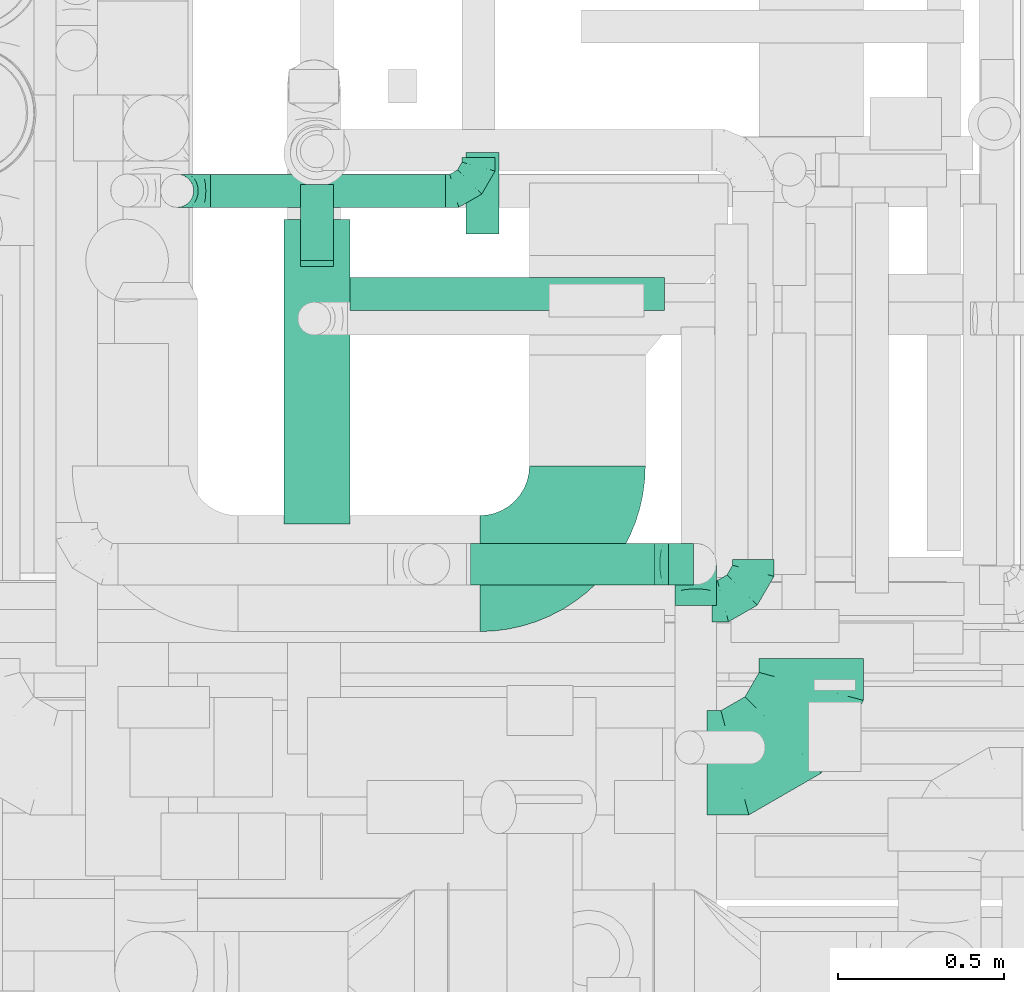
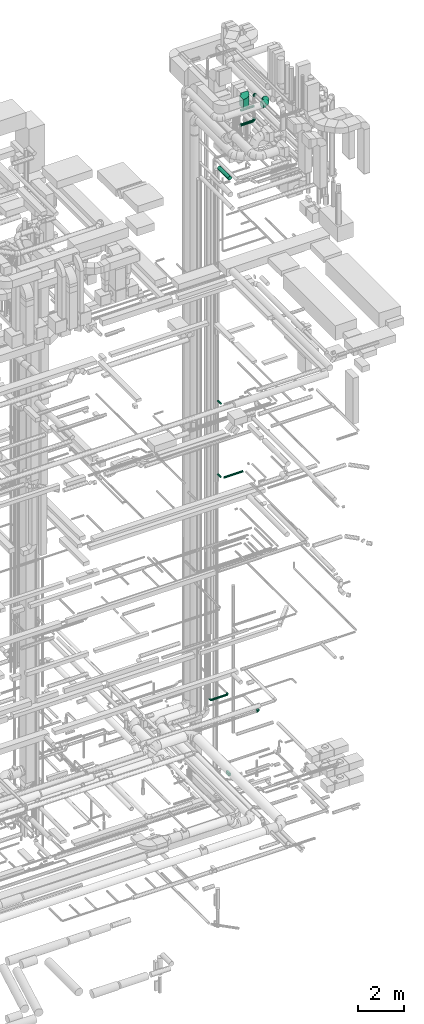
# One storey, part 264 of 337: 8 flow fittings, 8 flow segments.
"""IFC2X3 building model written with IfcOpenShell, lengths in millimetres."""

import ifcopenshell
import ifcopenshell.guid

model = None  # the IFC model being written
_history = None  # IfcOwnerHistory: only IFC2X3 demands one
_inside = {}  # id of a spatial element -> (the spatial element, [elements in it])
_under = {}  # id of a project, library or spatial element -> (it, [spatial elements below it])
_declared = {}  # id of a project -> (the project, [libraries it declares])
_typed = {}  # id of a type object -> (the type object, [elements of that type])
_made_of = {}  # id of a material, layer set ... -> (it, [elements and type objects made of it])


def new_model(schema):
    """Start an empty IFC model of exactly this schema.

    Asked for "IFC4X3", IfcOpenShell would pick the latest addendum, in which some entities
    have other attributes; the version numbers below select the first issue.
    IFC2X3 requires an IfcOwnerHistory on every rooted entity: one is made here for all.
    """
    global model, _history
    if schema == "IFC4X3":
        model = ifcopenshell.file(schema_version=(4, 3, 0, 0))
    else:
        model = ifcopenshell.file(schema=schema)
    _inside.clear()
    _under.clear()
    _declared.clear()
    _typed.clear()
    _made_of.clear()
    _history = None
    if model.schema == "IFC2X3":
        org = make("IfcOrganization", Name="unknown")
        user = make(
            "IfcPersonAndOrganization",
            ThePerson=make("IfcPerson", FamilyName="unknown"),
            TheOrganization=org,
        )
        app = make(
            "IfcApplication",
            ApplicationDeveloper=org,
            Version="unknown",
            ApplicationFullName="unknown",
            ApplicationIdentifier="unknown",
        )
        _history = make(
            "IfcOwnerHistory",
            OwningUser=user,
            OwningApplication=app,
            ChangeAction="ADDED",
            CreationDate=0,
        )
    return model


def make(cls, **values):
    """One entity of the class cls with the attributes given. An attribute that is None is left unset."""
    return model.create_entity(
        cls, **{name: value for name, value in values.items() if value is not None}
    )


def entity(cls, *values):
    """Any entity or typed value of the class cls, its attributes in the order of the schema. None: left unset."""
    e = model.create_entity(cls)
    for i, value in enumerate(values):
        if value is not None:
            e[i] = value
    return e


def rooted(cls, **values):
    """An entity with a GlobalId (a new one), such as an element, a storey or a relation."""
    return make(cls, GlobalId=ifcopenshell.guid.new(), OwnerHistory=_history, **values)


def si_unit(unit_type, name, prefix=None):
    """IfcSIUnit, for example si_unit("LENGTHUNIT", "METRE", prefix="MILLI")."""
    return make("IfcSIUnit", UnitType=unit_type, Prefix=prefix, Name=name)


def converted_unit(unit_type, name, factor, base, dimensions=None, offset=None):
    """IfcConversionBasedUnit, such as the inch: factor (a typed value) times the base unit."""
    return make(
        "IfcConversionBasedUnit"
        if offset is None
        else "IfcConversionBasedUnitWithOffset",
        ConversionOffset=offset,
        Dimensions=None
        if dimensions is None
        else entity("IfcDimensionalExponents", *dimensions),
        UnitType=unit_type,
        Name=name,
        ConversionFactor=make(
            "IfcMeasureWithUnit", ValueComponent=factor, UnitComponent=base
        ),
    )


def derived_unit(unit_type, elements):
    """IfcDerivedUnit: a product of units, each with its exponent."""
    return make(
        "IfcDerivedUnit",
        Elements=[
            make("IfcDerivedUnitElement", Unit=unit, Exponent=power)
            for unit, power in elements
        ],
        UnitType=unit_type,
    )


def assignment(units):
    """IfcUnitAssignment: the units of a project."""
    return None if units is None else make("IfcUnitAssignment", Units=units)


def point(xyz):
    """IfcCartesianPoint."""
    return None if xyz is None else make("IfcCartesianPoint", Coordinates=xyz)


def direction(xyz):
    """IfcDirection."""
    return None if xyz is None else make("IfcDirection", DirectionRatios=xyz)


def frame(location, z_axis=None, x_axis=None):
    """IfcAxis2Placement3D, a coordinate frame: its origin and axes. An axis left out is left unset."""
    return make(
        "IfcAxis2Placement3D",
        Location=point(location),
        Axis=direction(z_axis),
        RefDirection=direction(x_axis),
    )


def frame_2d(location, x_axis=None):
    """IfcAxis2Placement2D, a coordinate frame in the plane: its origin and x axis."""
    return make(
        "IfcAxis2Placement2D", Location=point(location), RefDirection=direction(x_axis)
    )


def origin():
    """The frame at (0, 0, 0) with its axes left unset."""
    return frame((0.0, 0.0, 0.0))


def origin_2d_with_axis():
    """The frame at (0, 0) in the plane with the x axis (1, 0) written out."""
    return frame_2d((0.0, 0.0), x_axis=(1.0, 0.0))


def place(relative_to, where):
    """IfcLocalPlacement: puts the frame where relative to a parent placement (None: the world)."""
    return make(
        "IfcLocalPlacement", PlacementRelTo=relative_to, RelativePlacement=where
    )


def context(
    kind, dimensions, precision=None, world=None, true_north=None, identifier=None
):
    """IfcGeometricRepresentationContext, for example the 3D "Model" context."""
    return make(
        "IfcGeometricRepresentationContext",
        ContextIdentifier=identifier,
        ContextType=kind,
        CoordinateSpaceDimension=dimensions,
        Precision=precision,
        WorldCoordinateSystem=world,
        TrueNorth=true_north,
    )


def subcontext(parent, identifier, kind, view, scale=None):
    """IfcGeometricRepresentationSubContext, for example "Body" below "Model"."""
    return make(
        "IfcGeometricRepresentationSubContext",
        ContextIdentifier=identifier,
        ContextType=kind,
        ParentContext=parent,
        TargetScale=scale,
        TargetView=view,
    )


def project(units=None, contexts=None):
    """IfcProject with its units and contexts."""
    return rooted(
        "IfcProject",
        Name="project",
        RepresentationContexts=contexts,
        UnitsInContext=assignment(units),
    )


def spatial(cls, under=None, at=None, **own):
    """A site, building, storey or space (cls), placed at a placement, below another one or the project."""
    s = rooted(cls, ObjectPlacement=at, **own)
    if under is not None:
        _under.setdefault(under.id(), (under, []))[1].append(s)
    return s


def polyline(points):
    """IfcPolyline through the points."""
    return make("IfcPolyline", Points=[point(p) for p in points])


def circle_curve(where, radius):
    """IfcCircle in the frame where."""
    return make("IfcCircle", Position=where, Radius=radius)


def parameter(value):
    """IfcParameterValue: where a trimmed curve begins or ends, as a parameter of its basis curve."""
    return model.create_entity("IfcParameterValue", value)


def trimmed(basis, trim1, trim2, sense, master):
    """IfcTrimmedCurve: the piece of a basis curve between two trims."""
    return make(
        "IfcTrimmedCurve",
        BasisCurve=basis,
        Trim1=trim1,
        Trim2=trim2,
        SenseAgreement=sense,
        MasterRepresentation=master,
    )


def segment(curve, same_sense, transition):
    """IfcCompositeCurveSegment."""
    return make(
        "IfcCompositeCurveSegment",
        Transition=transition,
        SameSense=same_sense,
        ParentCurve=curve,
    )


def composite_curve(segments, self_intersect=None):
    """IfcCompositeCurve: segments joined end to end."""
    return make("IfcCompositeCurve", Segments=segments, SelfIntersect=self_intersect)


def profile(cls, at=None, kind="AREA", **sizes):
    """A parametric profile (cls). Its sizes go by their IFC names, for example OverallWidth=200.0."""
    return make(cls, ProfileType=kind, Position=at, **sizes)


def rectangle(**sizes):
    """IfcRectangleProfileDef."""
    return profile("IfcRectangleProfileDef", **sizes)


def circle(**sizes):
    """IfcCircleProfileDef."""
    return profile("IfcCircleProfileDef", **sizes)


def outline(outer, holes=None, kind="AREA"):
    """IfcArbitraryClosedProfileDef: a profile drawn as a closed curve; with holes, ...WithVoids."""
    if holes is None:
        return make("IfcArbitraryClosedProfileDef", ProfileType=kind, OuterCurve=outer)
    return make(
        "IfcArbitraryProfileDefWithVoids",
        ProfileType=kind,
        OuterCurve=outer,
        InnerCurves=holes,
    )


def extrude(swept, where, along, depth):
    """IfcExtrudedAreaSolid: the profile swept, set in the frame where, extruded along a direction by depth."""
    return make(
        "IfcExtrudedAreaSolid",
        SweptArea=swept,
        Position=where,
        ExtrudedDirection=direction(along),
        Depth=depth,
    )


def faces_of(points, faces, orient=None, outer=None):
    """IfcFace entities. A face is a list of loops; a loop is a list of indices into points, from 0.

    orient and outer hold one flag for each loop. By default every Orientation is true, the
    first loop of a face is its IfcFaceOuterBound and the others are IfcFaceBound.
    """
    made = []
    for i, loops in enumerate(faces):
        bounds = []
        for j, loop in enumerate(loops):
            is_outer = j == 0 if outer is None else outer[i][j]
            bounds.append(
                make(
                    "IfcFaceOuterBound" if is_outer else "IfcFaceBound",
                    Bound=make("IfcPolyLoop", Polygon=[points[k] for k in loop]),
                    Orientation=True if orient is None else orient[i][j],
                )
            )
        made.append(make("IfcFace", Bounds=bounds))
    return made


def faceted_brep(points, faces, orient=None, outer=None, voids=None):
    """IfcFacetedBrep: a solid bounded by flat faces; with voids (closed shells), ...WithVoids."""
    shared = [point(p) for p in points]
    hull = make("IfcClosedShell", CfsFaces=faces_of(shared, faces, orient, outer))
    if voids is None:
        return make("IfcFacetedBrep", Outer=hull)
    return make(
        "IfcFacetedBrepWithVoids",
        Outer=hull,
        Voids=[
            make(cls, CfsFaces=faces_of(shared, fs, o, b)) for cls, fs, o, b in voids
        ],
    )


def shape(context_of_items, identifier, shape_type, items):
    """IfcShapeRepresentation: the items that make up one representation, for example the "Body"."""
    return make(
        "IfcShapeRepresentation",
        ContextOfItems=context_of_items,
        RepresentationIdentifier=identifier,
        RepresentationType=shape_type,
        Items=items,
    )


def source(mapping_origin, context_of_items, identifier, shape_type, items):
    """IfcRepresentationMap: a shape defined once, which mapped items show again and again."""
    return make(
        "IfcRepresentationMap",
        MappingOrigin=mapping_origin,
        MappedRepresentation=shape(context_of_items, identifier, shape_type, items),
    )


def transform(
    local_origin,
    x_axis=None,
    y_axis=None,
    z_axis=None,
    scale=None,
    scale2=None,
    scale3=None,
    uniform=True,
):
    """IfcCartesianTransformationOperator3D, or its non-uniform kind. x_axis, y_axis, z_axis: its Axis1, 2, 3."""
    if uniform:
        return make(
            "IfcCartesianTransformationOperator3D",
            Axis1=direction(x_axis),
            Axis2=direction(y_axis),
            LocalOrigin=point(local_origin),
            Scale=scale,
            Axis3=direction(z_axis),
        )
    return make(
        "IfcCartesianTransformationOperator3DnonUniform",
        Axis1=direction(x_axis),
        Axis2=direction(y_axis),
        LocalOrigin=point(local_origin),
        Scale=scale,
        Axis3=direction(z_axis),
        Scale2=scale2,
        Scale3=scale3,
    )


def mapped(mapping_source, mapping_target):
    """IfcMappedItem: shows the shape of a source again, moved by a transform."""
    return make(
        "IfcMappedItem", MappingSource=mapping_source, MappingTarget=mapping_target
    )


def material(Name=None, Category=None):
    """IfcMaterial."""
    return make("IfcMaterial", Name=Name, Category=Category)


def made_of(thing, what):
    """Note that an element or type object is made of a material, layer set ...; save() writes the relation."""
    if what is not None:
        _made_of.setdefault(what.id(), (what, []))[1].append(thing)
    return thing


def type_object(cls, material=None, **own):
    """A type object (cls), such as IfcWallType, which elements share."""
    return made_of(rooted(cls, **own), material)


def type_shapes(of_type, sources):
    """Give a type object the sources (RepresentationMaps) that its elements show as mapped items."""
    of_type.RepresentationMaps = sources


def element(
    cls,
    number,
    at=None,
    inside=None,
    cuts=None,
    type_object=None,
    material=None,
    context=None,
    identifier="Body",
    shape_type=None,
    held_by="IfcProductDefinitionShape",
    body=None,
    shapes=None,
    **own,
):
    """One element of the class cls, such as IfcWall. Its Tag is "e" and its number.

    at: its placement. inside: the storey or other place that contains it. cuts: it is an
    opening in that element (IfcRelVoidsElement). A single representation is given by context,
    identifier, shape_type and body (its items); several are given by shapes. held_by: the class
    of the entity that holds the representations. save() writes the other relations.
    """
    e = rooted(cls, Tag="e%d" % number, ObjectPlacement=at, **own)
    if body is not None:
        shapes = [shape(context, identifier, shape_type, body)]
    if shapes is not None:
        e.Representation = make(held_by, Representations=shapes)
    if inside is not None:
        _inside.setdefault(inside.id(), (inside, []))[1].append(e)
    if cuts is not None:
        rooted(
            "IfcRelVoidsElement", RelatingBuildingElement=cuts, RelatedOpeningElement=e
        )
    if type_object is not None:
        _typed.setdefault(type_object.id(), (type_object, []))[1].append(e)
    return made_of(e, material)


def aggregate(whole, parts):
    """IfcRelAggregates: a whole, such as a stair, and the parts it consists of."""
    return rooted("IfcRelAggregates", RelatingObject=whole, RelatedObjects=parts)


def save(model, path):
    """Write the relations noted so far, then the file.

    IfcRelAggregates (storeys below a building ...), IfcRelContainedInSpatialStructure (elements
    in a storey), IfcRelDefinesByType, IfcRelAssociatesMaterial and IfcRelDeclares: one each for
    every whole, place, type object, material and project.
    """
    for whole, parts in _under.values():
        aggregate(whole, parts)
    for where, things in _inside.values():
        rooted(
            "IfcRelContainedInSpatialStructure",
            RelatedElements=things,
            RelatingStructure=where,
        )
    for kind, things in _typed.values():
        rooted("IfcRelDefinesByType", RelatedObjects=things, RelatingType=kind)
    for what, things in _made_of.values():
        rooted("IfcRelAssociatesMaterial", RelatedObjects=things, RelatingMaterial=what)
    for by, libraries in _declared.values():
        rooted("IfcRelDeclares", RelatingContext=by, RelatedDefinitions=libraries)
    model.write(path)


model = new_model("IFC2X3")

# Units and contexts
model_context = context("Model", 3, precision=0.01, world=origin(), true_north=direction((6.12303176911189e-17, 1.0)))
body_context = subcontext(model_context, "Body", "Model", "MODEL_VIEW")
ifc_project = project(units=[si_unit("LENGTHUNIT", "METRE", prefix="MILLI"), si_unit("AREAUNIT", "SQUARE_METRE"), si_unit("VOLUMEUNIT", "CUBIC_METRE"), converted_unit("PLANEANGLEUNIT", "DEGREE", entity("IfcRatioMeasure", 0.0174532925199433), si_unit("PLANEANGLEUNIT", "RADIAN"), dimensions=[0, 0, 0, 0, 0, 0, 0]), si_unit("MASSUNIT", "GRAM", prefix="KILO"), derived_unit("MASSDENSITYUNIT", [(si_unit("MASSUNIT", "GRAM", prefix="KILO"), 1), (si_unit("LENGTHUNIT", "METRE"), -3)]), derived_unit("MOMENTOFINERTIAUNIT", [(si_unit("LENGTHUNIT", "METRE"), 4)]), si_unit("TIMEUNIT", "SECOND"), si_unit("FREQUENCYUNIT", "HERTZ"), si_unit("THERMODYNAMICTEMPERATUREUNIT", "DEGREE_CELSIUS"), derived_unit("THERMALTRANSMITTANCEUNIT", [(si_unit("MASSUNIT", "GRAM", prefix="KILO"), 1), (si_unit("THERMODYNAMICTEMPERATUREUNIT", "KELVIN"), -1), (si_unit("TIMEUNIT", "SECOND"), -3)]), derived_unit("VOLUMETRICFLOWRATEUNIT", [(si_unit("LENGTHUNIT", "METRE"), 3), (si_unit("TIMEUNIT", "SECOND"), -1)]), derived_unit("MASSFLOWRATEUNIT", [(si_unit("MASSUNIT", "GRAM", prefix="KILO"), 1), (si_unit("TIMEUNIT", "SECOND"), -1)]), derived_unit("ROTATIONALFREQUENCYUNIT", [(si_unit("TIMEUNIT", "SECOND"), -1)]), si_unit("ELECTRICCURRENTUNIT", "AMPERE"), si_unit("ELECTRICVOLTAGEUNIT", "VOLT"), si_unit("POWERUNIT", "WATT"), si_unit("FORCEUNIT", "NEWTON", prefix="KILO"), si_unit("ILLUMINANCEUNIT", "LUX"), si_unit("LUMINOUSFLUXUNIT", "LUMEN"), si_unit("LUMINOUSINTENSITYUNIT", "CANDELA"), derived_unit("USERDEFINED", [(si_unit("MASSUNIT", "GRAM", prefix="KILO"), -1), (si_unit("LENGTHUNIT", "METRE"), -2), (si_unit("TIMEUNIT", "SECOND"), 3), (si_unit("LUMINOUSFLUXUNIT", "LUMEN"), 1)]), derived_unit("LINEARVELOCITYUNIT", [(si_unit("LENGTHUNIT", "METRE"), 1), (si_unit("TIMEUNIT", "SECOND"), -1)]), si_unit("PRESSUREUNIT", "PASCAL"), derived_unit("USERDEFINED", [(si_unit("LENGTHUNIT", "METRE"), -2), (si_unit("MASSUNIT", "GRAM", prefix="KILO"), 1), (si_unit("TIMEUNIT", "SECOND"), -2)]), derived_unit("LINEARFORCEUNIT", [(si_unit("MASSUNIT", "GRAM", prefix="KILO"), 1), (si_unit("LENGTHUNIT", "METRE"), 1), (si_unit("TIMEUNIT", "SECOND"), -2), (si_unit("LENGTHUNIT", "METRE"), -1)]), derived_unit("PLANARFORCEUNIT", [(si_unit("MASSUNIT", "GRAM", prefix="KILO"), 1), (si_unit("LENGTHUNIT", "METRE"), 1), (si_unit("TIMEUNIT", "SECOND"), -2), (si_unit("LENGTHUNIT", "METRE"), -2)])], contexts=[model_context])

# Site, building, storey
site_placement = place(None, origin())
site = spatial("IfcSite", under=ifc_project, at=site_placement, CompositionType="ELEMENT")
building_placement = place(site_placement, origin())
building = spatial("IfcBuilding", under=site, at=building_placement, CompositionType="ELEMENT")
storey_placement = place(building_placement, origin())
storey = spatial("IfcBuildingStorey", under=building, at=storey_placement, CompositionType="ELEMENT", Elevation=0.0)

# Flow segments
duct_segment_type_1 = type_object("IfcDuctSegmentType", PredefinedType="NOTDEFINED")
flow_segment_1_placement = place(storey_placement, frame((69064.1, 11423.58, -750.0)))
element("IfcFlowSegment", 1, at=flow_segment_1_placement, inside=storey, type_object=duct_segment_type_1, context=body_context, shape_type="SweptSolid", body=[
    extrude(rectangle(XDim=246.447609999898, YDim=100.000000000003, at=origin_2d_with_axis()), frame((50.0, 123.22, 0.0), z_axis=(0.0, 0.0, 1.0), x_axis=(0.0, -1.0, 0.0)), (0.0, 0.0, 1.0), 150.0),
])
duct_segment_type_2 = type_object("IfcDuctSegmentType", PredefinedType="NOTDEFINED")
flow_segment_2_placement = place(storey_placement, frame((68714.23, 11191.71, 15248.4)))
element("IfcFlowSegment", 2, at=flow_segment_2_placement, inside=storey, type_object=duct_segment_type_2, context=body_context, shape_type="SweptSolid", body=[
    extrude(circle(Radius=50.0, at=origin_2d_with_axis()), frame((0.0, 51.6, 51.6), z_axis=(1.0, 0.0, 0.0), x_axis=(0.0, -1.0, 0.0)), (0.0, 0.0, 1.0), 949.254329999947),
])
flow_segment_3_placement = place(storey_placement, frame((68562.0, 11325.2, 19148.4)))
element("IfcFlowSegment", 3, at=flow_segment_3_placement, inside=storey, type_object=duct_segment_type_2, context=body_context, shape_type="SweptSolid", body=[
    extrude(circle(Radius=50.0, at=origin_2d_with_axis()), frame((51.6, 0.01, 51.6), z_axis=(0.000117343441141083, 0.999999993115258, 0.0), x_axis=(0.999999993115258, -0.000117343441141083, 0.0)), (0.0, 0.0, 1.0), 245.06931052787),
])
flow_segment_4_placement = place(storey_placement, frame((68562.63, 11343.31, 15248.4)))
element("IfcFlowSegment", 4, at=flow_segment_4_placement, inside=storey, type_object=duct_segment_type_2, context=body_context, shape_type="SweptSolid", body=[
    extrude(circle(Radius=50.0, at=origin_2d_with_axis()), frame((51.6, 0.0, 51.6), z_axis=(0.0, 1.0, 0.0), x_axis=(-1.0, 0.0, 0.0)), (0.0, 0.0, 1.0), 230.074907633675),
])
flow_segment_5_placement = place(storey_placement, frame((68291.62, 11502.7, 3448.4)))
element("IfcFlowSegment", 5, at=flow_segment_5_placement, inside=storey, type_object=duct_segment_type_2, context=body_context, shape_type="SweptSolid", body=[
    extrude(circle(Radius=50.0, at=origin_2d_with_axis()), frame((0.0, 51.6, 51.6), z_axis=(1.0, 0.0, 0.0), x_axis=(0.0, 1.0, 0.0)), (0.0, 0.0, 1.0), 710.00000000002),
])
flow_segment_6_placement = place(storey_placement, frame((69077.45, 10363.17, 35035.9)))
element("IfcFlowSegment", 6, at=flow_segment_6_placement, inside=storey, type_object=duct_segment_type_2, context=body_context, shape_type="SweptSolid", body=[
    extrude(circle(Radius=62.5, at=origin_2d_with_axis()), frame((0.0, 64.1, 64.1), z_axis=(1.0, 0.0, 0.0), x_axis=(0.0, 1.0, 0.0)), (0.0, 0.0, 1.0), 597.499999999864),
])
flow_segment_7_placement = place(storey_placement, frame((69064.95, 10363.17, 34255.9)))
element("IfcFlowSegment", 7, at=flow_segment_7_placement, inside=storey, type_object=duct_segment_type_2, context=body_context, shape_type="SweptSolid", body=[
    extrude(circle(Radius=62.5, at=origin_2d_with_axis()), frame((0.0, 64.1, 64.1), z_axis=(1.0, 0.0, 0.0), x_axis=(0.0, 1.0, 0.0)), (0.0, 0.0, 1.0), 567.49999999988),
])
flow_segment_8_placement = place(storey_placement, frame((68512.03, 10548.42, 31498.4)))
element("IfcFlowSegment", 8, at=flow_segment_8_placement, inside=storey, type_object=duct_segment_type_2, context=body_context, shape_type="SweptSolid", body=[
    extrude(circle(Radius=100.0, at=origin_2d_with_axis()), frame((101.6, 0.0, 101.6), z_axis=(0.0, 1.0, 0.0), x_axis=(1.0, 0.0, 0.0)), (0.0, 0.0, 1.0), 919.162419199703),
])

# Flow fittings
ifc_material = material()
duct_fitting_type_1 = type_object("IfcDuctFittingType", PredefinedType="NOTDEFINED", material=ifc_material)
shared_shape_1 = source(origin(), body_context, "Body", "Brep", [
    faceted_brep([(-100.0, 0.0, -50.0), (-100.0, -12.94, -48.3), (-100.0, -25.0, -43.3), (-100.0, -35.36, -35.36), (-100.0, -43.3, -25.0), (-100.0, -48.3, -12.94), (-100.0, -50.0, 0.0), (-100.0, -48.3, 12.94), (-100.0, -43.3, 25.0), (-100.0, -35.36, 35.36), (-100.0, -25.0, 43.3), (-100.0, -12.94, 48.3), (-100.0, 0.0, 50.0), (-100.0, 12.94, 48.3), (-100.0, 25.0, 43.3), (-100.0, 35.36, 35.36), (-100.0, 43.3, 25.0), (-100.0, 48.3, 12.94), (-100.0, 50.0, 0.0), (-100.0, 48.3, -12.94), (-100.0, 43.3, -25.0), (-100.0, 35.36, -35.36), (-100.0, 25.0, -43.3), (-100.0, 12.94, -48.3), (-76.67, 12.94, 48.3), (-79.9, 25.0, 43.3), (-73.21, 0.0, 50.0), (-82.68, 35.36, 35.36), (-86.15, 48.3, 12.94), (-86.6, 50.0, 0.0), (-84.81, 43.3, 25.0), (-84.81, 43.3, -25.0), (-82.68, 35.36, -35.36), (-86.15, 48.3, -12.94), (-76.67, 12.94, -48.3), (-73.21, 0.0, -50.0), (-79.9, 25.0, -43.3), (-69.74, -12.94, -48.3), (-66.51, -25.0, -43.3), (-63.73, -35.36, -35.36), (-61.6, -43.3, -25.0), (-60.26, -48.3, -12.94), (-59.81, -50.0, 0.0), (-60.26, -48.3, 12.94), (-61.6, -43.3, 25.0), (-63.73, -35.36, 35.36), (-66.51, -25.0, 43.3), (-69.74, -12.94, 48.3), (-36.27, 36.27, 48.3), (-45.1, 45.1, 43.3), (-26.79, 26.79, 50.0), (-52.68, 52.68, 35.36), (-58.49, 58.49, 25.0), (-62.15, 62.15, 12.94), (-63.4, 63.4, 0.0), (-62.15, 62.15, -12.94), (-58.49, 58.49, -25.0), (-52.68, 52.68, -35.36), (-36.27, 36.27, -48.3), (-26.79, 26.79, -50.0), (-45.1, 45.1, -43.3), (-17.32, 17.32, -48.3), (-8.49, 8.49, -43.3), (-0.91, 0.91, -35.36), (4.9, -4.9, -25.0), (8.56, -8.56, -12.94), (9.81, -9.81, 0.0), (8.56, -8.56, 12.94), (4.9, -4.9, 25.0), (-0.91, 0.91, 35.36), (-8.49, 8.49, 43.3), (-17.32, 17.32, 48.3), (-12.94, 76.67, 48.3), (-25.0, 79.9, 43.3), (0.0, 73.21, 50.0), (-35.36, 82.68, 35.36), (-43.3, 84.81, 25.0), (-48.3, 86.15, 12.94), (-50.0, 86.6, 0.0), (-48.3, 86.15, -12.94), (-43.3, 84.81, -25.0), (-35.36, 82.68, -35.36), (-12.94, 76.67, -48.3), (0.0, 73.21, -50.0), (-25.0, 79.9, -43.3), (12.94, 69.74, -48.3), (25.0, 66.51, -43.3), (35.36, 63.73, -35.36), (43.3, 61.6, -25.0), (48.3, 60.26, -12.94), (50.0, 59.81, 0.0), (48.3, 60.26, 12.94), (43.3, 61.6, 25.0), (35.36, 63.73, 35.36), (25.0, 66.51, 43.3), (12.94, 69.74, 48.3), (-12.94, 100.0, -48.3), (-25.0, 100.0, -43.3), (-35.36, 100.0, -35.36), (-43.3, 100.0, -25.0), (-48.3, 100.0, -12.94), (-50.0, 100.0, 0.0), (-48.3, 100.0, 12.94), (-43.3, 100.0, 25.0), (-35.36, 100.0, 35.36), (-25.0, 100.0, 43.3), (-12.94, 100.0, 48.3), (0.0, 100.0, 50.0), (12.94, 100.0, 48.3), (25.0, 100.0, 43.3), (35.36, 100.0, 35.36), (43.3, 100.0, 25.0), (48.3, 100.0, 12.94), (50.0, 100.0, 0.0), (48.3, 100.0, -12.94), (43.3, 100.0, -25.0), (35.36, 100.0, -35.36), (25.0, 100.0, -43.3), (12.94, 100.0, -48.3), (0.0, 100.0, -50.0)], [[[0, 1, 2, 3, 4, 5, 6, 7, 8, 9, 10, 11, 12, 13, 14, 15, 16, 17, 18, 19, 20, 21, 22, 23]], [[24, 25, 14, 13]], [[26, 24, 13, 12]], [[14, 25, 27, 15]], [[28, 29, 18, 17]], [[30, 28, 17, 16]], [[15, 27, 30, 16]], [[20, 31, 32, 21]], [[33, 31, 20, 19]], [[18, 29, 33, 19]], [[34, 35, 0, 23]], [[36, 34, 23, 22]], [[32, 36, 22, 21]], [[2, 1, 37, 38]], [[3, 2, 38, 39]], [[0, 35, 37, 1]], [[5, 4, 40, 41]], [[6, 5, 41, 42]], [[3, 39, 40, 4]], [[6, 42, 43, 7]], [[7, 43, 44, 8]], [[8, 44, 45, 9]], [[10, 46, 47, 11]], [[11, 47, 26, 12]], [[10, 9, 45, 46]], [[48, 49, 25, 24]], [[50, 48, 24, 26]], [[27, 25, 49, 51]], [[52, 53, 28, 30]], [[51, 52, 30, 27]], [[29, 28, 53, 54]], [[55, 56, 31, 33]], [[54, 55, 33, 29]], [[57, 32, 31, 56]], [[58, 59, 35, 34]], [[60, 58, 34, 36]], [[57, 60, 36, 32]], [[37, 35, 59, 61]], [[38, 37, 61, 62]], [[39, 38, 62, 63]], [[41, 40, 64, 65]], [[42, 41, 65, 66]], [[63, 64, 40, 39]], [[43, 42, 66, 67]], [[44, 43, 67, 68]], [[68, 69, 45, 44]], [[46, 45, 69, 70]], [[47, 46, 70, 71]], [[26, 47, 71, 50]], [[72, 73, 49, 48]], [[74, 72, 48, 50]], [[51, 49, 73, 75]], [[76, 77, 53, 52]], [[75, 76, 52, 51]], [[54, 53, 77, 78]], [[79, 80, 56, 55]], [[78, 79, 55, 54]], [[81, 57, 56, 80]], [[82, 83, 59, 58]], [[84, 82, 58, 60]], [[81, 84, 60, 57]], [[61, 59, 83, 85]], [[62, 61, 85, 86]], [[63, 62, 86, 87]], [[65, 64, 88, 89]], [[66, 65, 89, 90]], [[87, 88, 64, 63]], [[67, 66, 90, 91]], [[68, 67, 91, 92]], [[92, 93, 69, 68]], [[70, 69, 93, 94]], [[71, 70, 94, 95]], [[50, 71, 95, 74]], [[96, 97, 98, 99, 100, 101, 102, 103, 104, 105, 106, 107, 108, 109, 110, 111, 112, 113, 114, 115, 116, 117, 118, 119]], [[72, 74, 107, 106]], [[73, 72, 106, 105]], [[75, 73, 105, 104]], [[77, 76, 103, 102]], [[78, 77, 102, 101]], [[75, 104, 103, 76]], [[78, 101, 100, 79]], [[79, 100, 99, 80]], [[80, 99, 98, 81]], [[96, 119, 83, 82]], [[97, 96, 82, 84]], [[84, 81, 98, 97]], [[83, 119, 118, 85]], [[85, 118, 117, 86]], [[86, 117, 116, 87]], [[88, 115, 114, 89]], [[89, 114, 113, 90]], [[87, 116, 115, 88]], [[91, 90, 113, 112]], [[92, 91, 112, 111]], [[93, 92, 111, 110]], [[95, 94, 109, 108]], [[74, 95, 108, 107]], [[110, 109, 94, 93]]]),
])
type_shapes(duct_fitting_type_1, [shared_shape_1])
flow_fitting_1_placement = place(storey_placement, frame((69101.62, 11554.29, 3500.0)))
element("IfcFlowFitting", 9, at=flow_fitting_1_placement, inside=storey, type_object=duct_fitting_type_1, material=ifc_material, context=body_context, shape_type="MappedRepresentation", body=[
    mapped(shared_shape_1, transform((0.0, 0.0, 0.0), scale=1.0)),
])
flow_fitting_2_placement = place(storey_placement, frame((68191.62, 11554.29, 3500.0), z_axis=(0.0, 1.0, 0.0), x_axis=(-1.0, 0.0, 0.0)))
element("IfcFlowFitting", 10, at=flow_fitting_2_placement, inside=storey, type_object=duct_fitting_type_1, material=ifc_material, context=body_context, shape_type="MappedRepresentation", body=[
    mapped(shared_shape_1, transform((0.0, 0.0, 0.0), scale=1.0)),
])
duct_fitting_type_2 = type_object("IfcDuctFittingType", PredefinedType="NOTDEFINED", material=ifc_material)
shared_shape_2 = source(origin(), body_context, "Body", "Brep", [
    faceted_brep([(-125.0, 0.0, -62.5), (-125.0, -16.18, -60.37), (-125.0, -31.25, -54.13), (-125.0, -44.19, -44.19), (-125.0, -54.13, -31.25), (-125.0, -60.37, -16.18), (-125.0, -62.5, 0.0), (-125.0, -60.37, 16.18), (-125.0, -54.13, 31.25), (-125.0, -44.19, 44.19), (-125.0, -31.25, 54.13), (-125.0, -16.18, 60.37), (-125.0, 0.0, 62.5), (-125.0, 16.18, 60.37), (-125.0, 31.25, 54.13), (-125.0, 44.19, 44.19), (-125.0, 54.13, 31.25), (-125.0, 60.37, 16.18), (-125.0, 62.5, 0.0), (-125.0, 60.37, -16.18), (-125.0, 54.13, -31.25), (-125.0, 44.19, -44.19), (-125.0, 31.25, -54.13), (-125.0, 16.18, -60.37), (-95.84, 16.18, 60.37), (-99.88, 31.25, 54.13), (-91.51, 0.0, 62.5), (-103.35, 44.19, 44.19), (-107.68, 60.37, 16.18), (-108.25, 62.5, 0.0), (-106.01, 54.13, 31.25), (-106.01, 54.13, -31.25), (-103.35, 44.19, -44.19), (-107.68, 60.37, -16.18), (-95.84, 16.18, -60.37), (-91.51, 0.0, -62.5), (-99.88, 31.25, -54.13), (-87.17, -16.18, -60.37), (-83.13, -31.25, -54.13), (-79.66, -44.19, -44.19), (-77.0, -54.13, -31.25), (-75.33, -60.37, -16.18), (-74.76, -62.5, 0.0), (-75.33, -60.37, 16.18), (-77.0, -54.13, 31.25), (-79.66, -44.19, 44.19), (-83.13, -31.25, 54.13), (-87.17, -16.18, 60.37), (-45.34, 45.34, 60.37), (-56.37, 56.37, 54.13), (-33.49, 33.49, 62.5), (-65.85, 65.85, 44.19), (-73.12, 73.12, 31.25), (-77.69, 77.69, 16.18), (-79.25, 79.25, 0.0), (-77.69, 77.69, -16.18), (-73.12, 73.12, -31.25), (-65.85, 65.85, -44.19), (-45.34, 45.34, -60.37), (-33.49, 33.49, -62.5), (-56.37, 56.37, -54.13), (-21.65, 21.65, -60.37), (-10.62, 10.62, -54.13), (-1.14, 1.14, -44.19), (6.13, -6.13, -31.25), (10.7, -10.7, -16.18), (12.26, -12.26, 0.0), (10.7, -10.7, 16.18), (6.13, -6.13, 31.25), (-1.14, 1.14, 44.19), (-10.62, 10.62, 54.13), (-21.65, 21.65, 60.37), (-16.18, 95.84, 60.37), (-31.25, 99.88, 54.13), (0.0, 91.51, 62.5), (-44.19, 103.35, 44.19), (-54.13, 106.01, 31.25), (-60.37, 107.68, 16.18), (-62.5, 108.25, 0.0), (-60.37, 107.68, -16.18), (-54.13, 106.01, -31.25), (-44.19, 103.35, -44.19), (-16.18, 95.84, -60.37), (0.0, 91.51, -62.5), (-31.25, 99.88, -54.13), (16.18, 87.17, -60.37), (31.25, 83.13, -54.13), (44.19, 79.66, -44.19), (54.13, 77.0, -31.25), (60.37, 75.33, -16.18), (62.5, 74.76, 0.0), (60.37, 75.33, 16.18), (54.13, 77.0, 31.25), (44.19, 79.66, 44.19), (31.25, 83.13, 54.13), (16.18, 87.17, 60.37), (-16.18, 125.0, -60.37), (-31.25, 125.0, -54.13), (-44.19, 125.0, -44.19), (-54.13, 125.0, -31.25), (-60.37, 125.0, -16.18), (-62.5, 125.0, 0.0), (-60.37, 125.0, 16.18), (-54.13, 125.0, 31.25), (-44.19, 125.0, 44.19), (-31.25, 125.0, 54.13), (-16.18, 125.0, 60.37), (0.0, 125.0, 62.5), (16.18, 125.0, 60.37), (31.25, 125.0, 54.13), (44.19, 125.0, 44.19), (54.13, 125.0, 31.25), (60.37, 125.0, 16.18), (62.5, 125.0, 0.0), (60.37, 125.0, -16.18), (54.13, 125.0, -31.25), (44.19, 125.0, -44.19), (31.25, 125.0, -54.13), (16.18, 125.0, -60.37), (0.0, 125.0, -62.5)], [[[0, 1, 2, 3, 4, 5, 6, 7, 8, 9, 10, 11, 12, 13, 14, 15, 16, 17, 18, 19, 20, 21, 22, 23]], [[24, 25, 14, 13]], [[26, 24, 13, 12]], [[14, 25, 27, 15]], [[28, 29, 18, 17]], [[30, 28, 17, 16]], [[15, 27, 30, 16]], [[20, 31, 32, 21]], [[33, 31, 20, 19]], [[18, 29, 33, 19]], [[34, 35, 0, 23]], [[36, 34, 23, 22]], [[21, 32, 36, 22]], [[1, 0, 35, 37]], [[2, 1, 37, 38]], [[38, 39, 3, 2]], [[5, 4, 40, 41]], [[6, 5, 41, 42]], [[39, 40, 4, 3]], [[6, 42, 43, 7]], [[7, 43, 44, 8]], [[45, 9, 8, 44]], [[9, 45, 46, 10]], [[10, 46, 47, 11]], [[26, 12, 11, 47]], [[48, 49, 25, 24]], [[50, 48, 24, 26]], [[27, 25, 49, 51]], [[52, 53, 28, 30]], [[51, 52, 30, 27]], [[29, 28, 53, 54]], [[55, 56, 31, 33]], [[54, 55, 33, 29]], [[57, 32, 31, 56]], [[58, 59, 35, 34]], [[60, 58, 34, 36]], [[57, 60, 36, 32]], [[37, 35, 59, 61]], [[38, 37, 61, 62]], [[39, 38, 62, 63]], [[41, 40, 64, 65]], [[42, 41, 65, 66]], [[63, 64, 40, 39]], [[43, 42, 66, 67]], [[44, 43, 67, 68]], [[68, 69, 45, 44]], [[46, 45, 69, 70]], [[47, 46, 70, 71]], [[26, 47, 71, 50]], [[72, 73, 49, 48]], [[74, 72, 48, 50]], [[51, 49, 73, 75]], [[76, 77, 53, 52]], [[75, 76, 52, 51]], [[54, 53, 77, 78]], [[79, 80, 56, 55]], [[78, 79, 55, 54]], [[81, 57, 56, 80]], [[82, 83, 59, 58]], [[84, 82, 58, 60]], [[81, 84, 60, 57]], [[61, 59, 83, 85]], [[62, 61, 85, 86]], [[63, 62, 86, 87]], [[65, 64, 88, 89]], [[66, 65, 89, 90]], [[87, 88, 64, 63]], [[67, 66, 90, 91]], [[68, 67, 91, 92]], [[92, 93, 69, 68]], [[70, 69, 93, 94]], [[71, 70, 94, 95]], [[50, 71, 95, 74]], [[96, 97, 98, 99, 100, 101, 102, 103, 104, 105, 106, 107, 108, 109, 110, 111, 112, 113, 114, 115, 116, 117, 118, 119]], [[72, 74, 107, 106]], [[73, 72, 106, 105]], [[75, 73, 105, 104]], [[77, 76, 103, 102]], [[78, 77, 102, 101]], [[75, 104, 103, 76]], [[78, 101, 100, 79]], [[79, 100, 99, 80]], [[80, 99, 98, 81]], [[96, 119, 83, 82]], [[97, 96, 82, 84]], [[84, 81, 98, 97]], [[83, 119, 118, 85]], [[85, 118, 117, 86]], [[116, 87, 86, 117]], [[88, 115, 114, 89]], [[89, 114, 113, 90]], [[115, 88, 87, 116]], [[91, 90, 113, 112]], [[92, 91, 112, 111]], [[111, 110, 93, 92]], [[95, 94, 109, 108]], [[74, 95, 108, 107]], [[110, 109, 94, 93]]]),
])
type_shapes(duct_fitting_type_2, [shared_shape_2])
for number, where, z_axis, x_axis in (
    (11, (69757.45, 10427.27, 35750.0), (-1.0, 0.0, 0.0), (0.0, 1.0, 0.0)),
    (12, (69757.45, 10427.27, 34320.0), (0.0, 1.0, 0.0), (0.0, 0.0, -1.0)),
):
    element("IfcFlowFitting", number, at=place(storey_placement, frame(where, z_axis=z_axis, x_axis=x_axis)), inside=storey, type_object=duct_fitting_type_2, material=ifc_material, context=body_context, shape_type="MappedRepresentation", body=[
        mapped(shared_shape_2, transform((0.0, 0.0, 0.0), scale=1.0)),
    ])
flow_fitting_3_placement = place(storey_placement, frame((69931.21, 10315.5, 3100.0)))
element("IfcFlowFitting", 13, at=flow_fitting_3_placement, inside=storey, type_object=duct_fitting_type_2, material=ifc_material, context=body_context, shape_type="MappedRepresentation", body=[
    mapped(shared_shape_2, transform((0.0, 0.0, 0.0), scale=1.0)),
])
duct_fitting_type_3 = type_object("IfcDuctFittingType", PredefinedType="NOTDEFINED", material=ifc_material)
shared_shape_3 = source(origin(), body_context, "Body", "Brep", [
    faceted_brep([(-315.0, 0.0, -157.5), (-315.0, -40.76, -152.13), (-315.0, -78.75, -136.4), (-315.0, -111.37, -111.37), (-315.0, -136.4, -78.75), (-315.0, -152.13, -40.76), (-315.0, -157.5, 0.0), (-315.0, -152.13, 40.76), (-315.0, -136.4, 78.75), (-315.0, -111.37, 111.37), (-315.0, -78.75, 136.4), (-315.0, -40.76, 152.13), (-315.0, 0.0, 157.5), (-315.0, 40.76, 152.13), (-315.0, 78.75, 136.4), (-315.0, 111.37, 111.37), (-315.0, 136.4, 78.75), (-315.0, 152.13, 40.76), (-315.0, 157.5, 0.0), (-315.0, 152.13, -40.76), (-315.0, 136.4, -78.75), (-315.0, 111.37, -111.37), (-315.0, 78.75, -136.4), (-315.0, 40.76, -152.13), (-241.52, 40.76, 152.13), (-251.7, 78.75, 136.4), (-230.6, 0.0, 157.5), (-260.44, 111.37, 111.37), (-271.36, 152.13, 40.76), (-272.8, 157.5, 0.0), (-267.14, 136.4, 78.75), (-267.14, 136.4, -78.75), (-260.44, 111.37, -111.37), (-271.36, 152.13, -40.76), (-241.52, 40.76, -152.13), (-230.6, 0.0, -157.5), (-251.7, 78.75, -136.4), (-219.67, -40.76, -152.13), (-209.5, -78.75, -136.4), (-200.75, -111.37, -111.37), (-194.05, -136.4, -78.75), (-189.83, -152.13, -40.76), (-188.39, -157.5, 0.0), (-189.83, -152.13, 40.76), (-194.05, -136.4, 78.75), (-200.75, -111.37, 111.37), (-209.5, -78.75, 136.4), (-219.67, -40.76, 152.13), (-114.25, 114.25, 152.13), (-142.05, 142.05, 136.4), (-84.4, 84.4, 157.5), (-165.93, 165.93, 111.37), (-184.25, 184.25, 78.75), (-195.77, 195.77, 40.76), (-199.7, 199.7, 0.0), (-195.77, 195.77, -40.76), (-184.25, 184.25, -78.75), (-165.93, 165.93, -111.37), (-114.25, 114.25, -152.13), (-84.4, 84.4, -157.5), (-142.05, 142.05, -136.4), (-54.56, 54.56, -152.13), (-26.75, 26.75, -136.4), (-2.88, 2.88, -111.37), (15.45, -15.45, -78.75), (26.97, -26.97, -40.76), (30.89, -30.89, 0.0), (26.97, -26.97, 40.76), (15.45, -15.45, 78.75), (-2.88, 2.88, 111.37), (-26.75, 26.75, 136.4), (-54.56, 54.56, 152.13), (-40.76, 241.52, 152.13), (-78.75, 251.7, 136.4), (0.0, 230.6, 157.5), (-111.37, 260.44, 111.37), (-136.4, 267.14, 78.75), (-152.13, 271.36, 40.76), (-157.5, 272.8, 0.0), (-152.13, 271.36, -40.76), (-136.4, 267.14, -78.75), (-111.37, 260.44, -111.37), (-40.76, 241.52, -152.13), (0.0, 230.6, -157.5), (-78.75, 251.7, -136.4), (40.76, 219.67, -152.13), (78.75, 209.5, -136.4), (111.37, 200.75, -111.37), (136.4, 194.05, -78.75), (152.13, 189.83, -40.76), (157.5, 188.39, 0.0), (152.13, 189.83, 40.76), (136.4, 194.05, 78.75), (111.37, 200.75, 111.37), (78.75, 209.5, 136.4), (40.76, 219.67, 152.13), (-40.76, 315.0, -152.13), (-78.75, 315.0, -136.4), (-111.37, 315.0, -111.37), (-136.4, 315.0, -78.75), (-152.13, 315.0, -40.76), (-157.5, 315.0, 0.0), (-152.13, 315.0, 40.76), (-136.4, 315.0, 78.75), (-111.37, 315.0, 111.37), (-78.75, 315.0, 136.4), (-40.76, 315.0, 152.13), (0.0, 315.0, 157.5), (40.76, 315.0, 152.13), (78.75, 315.0, 136.4), (111.37, 315.0, 111.37), (136.4, 315.0, 78.75), (152.13, 315.0, 40.76), (157.5, 315.0, 0.0), (152.13, 315.0, -40.76), (136.4, 315.0, -78.75), (111.37, 315.0, -111.37), (78.75, 315.0, -136.4), (40.76, 315.0, -152.13), (0.0, 315.0, -157.5)], [[[0, 1, 2, 3, 4, 5, 6, 7, 8, 9, 10, 11, 12, 13, 14, 15, 16, 17, 18, 19, 20, 21, 22, 23]], [[24, 25, 14, 13]], [[26, 24, 13, 12]], [[14, 25, 27, 15]], [[28, 29, 18, 17]], [[30, 28, 17, 16]], [[15, 27, 30, 16]], [[20, 31, 32, 21]], [[33, 31, 20, 19]], [[18, 29, 33, 19]], [[34, 35, 0, 23]], [[36, 34, 23, 22]], [[32, 36, 22, 21]], [[1, 0, 35, 37]], [[2, 1, 37, 38]], [[38, 39, 3, 2]], [[5, 4, 40, 41]], [[6, 5, 41, 42]], [[39, 40, 4, 3]], [[6, 42, 43, 7]], [[7, 43, 44, 8]], [[8, 44, 45, 9]], [[9, 45, 46, 10]], [[10, 46, 47, 11]], [[26, 12, 11, 47]], [[48, 49, 25, 24]], [[50, 48, 24, 26]], [[27, 25, 49, 51]], [[52, 53, 28, 30]], [[51, 52, 30, 27]], [[29, 28, 53, 54]], [[55, 56, 31, 33]], [[54, 55, 33, 29]], [[32, 31, 56, 57]], [[58, 59, 35, 34]], [[60, 58, 34, 36]], [[57, 60, 36, 32]], [[37, 35, 59, 61]], [[38, 37, 61, 62]], [[39, 38, 62, 63]], [[41, 40, 64, 65]], [[42, 41, 65, 66]], [[63, 64, 40, 39]], [[43, 42, 66, 67]], [[44, 43, 67, 68]], [[68, 69, 45, 44]], [[46, 45, 69, 70]], [[47, 46, 70, 71]], [[26, 47, 71, 50]], [[72, 73, 49, 48]], [[74, 72, 48, 50]], [[51, 49, 73, 75]], [[76, 77, 53, 52]], [[75, 76, 52, 51]], [[54, 53, 77, 78]], [[79, 80, 56, 55]], [[78, 79, 55, 54]], [[57, 56, 80, 81]], [[82, 83, 59, 58]], [[84, 82, 58, 60]], [[81, 84, 60, 57]], [[61, 59, 83, 85]], [[62, 61, 85, 86]], [[63, 62, 86, 87]], [[65, 64, 88, 89]], [[66, 65, 89, 90]], [[87, 88, 64, 63]], [[67, 66, 90, 91]], [[68, 67, 91, 92]], [[92, 93, 69, 68]], [[70, 69, 93, 94]], [[71, 70, 94, 95]], [[50, 71, 95, 74]], [[96, 97, 98, 99, 100, 101, 102, 103, 104, 105, 106, 107, 108, 109, 110, 111, 112, 113, 114, 115, 116, 117, 118, 119]], [[106, 105, 73, 72]], [[107, 106, 72, 74]], [[75, 73, 105, 104]], [[77, 76, 103, 102]], [[78, 77, 102, 101]], [[104, 103, 76, 75]], [[78, 101, 100, 79]], [[79, 100, 99, 80]], [[98, 81, 80, 99]], [[84, 97, 96, 82]], [[82, 96, 119, 83]], [[97, 84, 81, 98]], [[83, 119, 118, 85]], [[85, 118, 117, 86]], [[116, 87, 86, 117]], [[88, 115, 114, 89]], [[89, 114, 113, 90]], [[115, 88, 87, 116]], [[91, 90, 113, 112]], [[92, 91, 112, 111]], [[111, 110, 93, 92]], [[95, 94, 109, 108]], [[74, 95, 108, 107]], [[110, 109, 94, 93]]]),
])
type_shapes(duct_fitting_type_3, [shared_shape_3])
flow_fitting_4_placement = place(storey_placement, frame((70106.26, 9827.35, 35520.0)))
element("IfcFlowFitting", 14, at=flow_fitting_4_placement, inside=storey, type_object=duct_fitting_type_3, material=ifc_material, context=body_context, shape_type="MappedRepresentation", body=[
    mapped(shared_shape_3, transform((0.0, 0.0, 0.0), scale=1.0)),
])
duct_fitting_type_4 = type_object("IfcDuctFittingType", PredefinedType="NOTDEFINED", material=ifc_material)
shared_shape_4 = source(origin(), body_context, "Body", "Brep", [
    faceted_brep([(20.0, 16.18, -60.37), (20.0, 31.25, -54.13), (20.0, 44.19, -44.19), (20.0, 54.13, -31.25), (20.0, 60.37, -16.18), (20.0, 62.5, 0.0), (20.0, 60.37, 16.18), (20.0, 54.13, 31.25), (20.0, 44.19, 44.19), (20.0, 31.25, 54.13), (20.0, 16.18, 60.37), (20.0, 0.0, 62.5), (20.0, -16.18, 60.37), (20.0, -31.25, 54.13), (20.0, -44.19, 44.19), (20.0, -54.13, 31.25), (20.0, -60.37, 16.18), (20.0, -62.5, 0.0), (20.0, -60.37, -16.18), (20.0, -54.13, -31.25), (20.0, -44.19, -44.19), (20.0, -31.25, -54.13), (20.0, -16.18, -60.37), (20.0, 0.0, -62.5), (0.0, 0.0, 62.5), (0.0, 16.18, 60.37), (-56.4, 16.18, 60.37), (-56.4, 0.0, 62.5), (0.0, 31.25, 54.13), (-56.4, 31.25, 54.13), (0.0, 44.19, 44.19), (-56.4, 44.19, 44.19), (0.0, 54.13, 31.25), (0.0, 60.37, 16.18), (-56.4, 60.37, 16.18), (-56.4, 54.13, 31.25), (0.0, 62.5, 0.0), (-56.4, 62.5, 0.0), (0.0, 60.37, -16.18), (-56.4, 60.37, -16.18), (0.0, 54.13, -31.25), (-56.4, 54.13, -31.25), (0.0, 44.19, -44.19), (-56.4, 44.19, -44.19), (0.0, 31.25, -54.13), (0.0, 16.18, -60.37), (-56.4, 16.18, -60.37), (-56.4, 31.25, -54.13), (0.0, 0.0, -62.5), (-56.4, 0.0, -62.5), (0.0, -16.18, -60.37), (-56.4, -16.18, -60.37), (0.0, -31.25, -54.13), (-56.4, -31.25, -54.13), (0.0, -44.19, -44.19), (-56.4, -44.19, -44.19), (0.0, -54.13, -31.25), (0.0, -60.37, -16.18), (-56.4, -60.37, -16.18), (-56.4, -54.13, -31.25), (0.0, -62.5, 0.0), (-56.4, -62.5, 0.0), (0.0, -60.37, 16.18), (-56.4, -60.37, 16.18), (0.0, -54.13, 31.25), (-56.4, -54.13, 31.25), (0.0, -44.19, 44.19), (-56.4, -44.19, 44.19), (0.0, -31.25, 54.13), (0.0, -16.18, 60.37), (-56.4, -16.18, 60.37), (-56.4, -31.25, 54.13)], [[[0, 1, 2, 3, 4, 5, 6, 7, 8, 9, 10, 11, 12, 13, 14, 15, 16, 17, 18, 19, 20, 21, 22, 23]], [[24, 11, 10, 25, 26, 27]], [[25, 10, 9, 28, 29, 26]], [[28, 9, 8, 30, 31, 29]], [[32, 7, 6, 33, 34, 35]], [[33, 6, 5, 36, 37, 34]], [[30, 8, 7, 32, 35, 31]], [[36, 5, 4, 38, 39, 37]], [[38, 4, 3, 40, 41, 39]], [[40, 3, 2, 42, 43, 41]], [[44, 1, 0, 45, 46, 47]], [[45, 0, 23, 48, 49, 46]], [[42, 2, 1, 44, 47, 43]], [[48, 23, 22, 50, 51, 49]], [[50, 22, 21, 52, 53, 51]], [[52, 21, 20, 54, 55, 53]], [[56, 19, 18, 57, 58, 59]], [[57, 18, 17, 60, 61, 58]], [[54, 20, 19, 56, 59, 55]], [[60, 17, 16, 62, 63, 61]], [[62, 16, 15, 64, 65, 63]], [[64, 15, 14, 66, 67, 65]], [[68, 13, 12, 69, 70, 71]], [[69, 12, 11, 24, 27, 70]], [[66, 14, 13, 68, 71, 67]], [[49, 51, 53, 55, 59, 58, 61, 63, 65, 67, 71, 70, 27, 26, 29, 31, 35, 34, 37, 39, 41, 43, 47, 46]]]),
])
type_shapes(duct_fitting_type_4, [shared_shape_4])
flow_fitting_5_placement = place(storey_placement, frame((69694.95, 10427.27, 35100.0), z_axis=(0.0, 1.0, 0.0), x_axis=(-1.0, 0.0, 0.0)))
element("IfcFlowFitting", 15, at=flow_fitting_5_placement, inside=storey, type_object=duct_fitting_type_4, material=ifc_material, context=body_context, shape_type="MappedRepresentation", body=[
    mapped(shared_shape_4, transform((0.0, 0.0, 0.0), scale=1.0)),
])
duct_fitting_type_5 = type_object("IfcDuctFittingType", PredefinedType="NOTDEFINED", material=ifc_material)
shared_shape_5 = source(origin(), body_context, "Body", "SweptSolid", [
    extrude(outline(composite_curve([segment(polyline([(-337.5, -162.5), (12.5, -162.5)]), True, "CONTINUOUS"), segment(trimmed(circle_curve(frame_2d((162.5, -162.5), x_axis=(0.0, 1.0)), 150.0), [parameter(0.0)], [parameter(90.0000000000001)], True, "PARAMETER"), False, "CONTINUOUS"), segment(polyline([(162.5, -12.5), (162.5, 337.5)]), True, "CONTINUOUS"), segment(trimmed(circle_curve(frame_2d((162.5, -162.5), x_axis=(0.0, 1.0)), 500.0), [parameter(0.0)], [parameter(90.0000000000001)], True, "PARAMETER"), True, "CONTINUOUS")], self_intersect=False)), frame((-162.5, 162.5, -250.0), z_axis=(0.0, 0.0, 1.0), x_axis=(-1.0, 0.0, 0.0)), (0.0, 0.0, 1.0), 500.0),
])
type_shapes(duct_fitting_type_5, [shared_shape_5])
flow_fitting_6_placement = place(storey_placement, frame((69430.37, 10398.58, 35530.0)))
element("IfcFlowFitting", 16, at=flow_fitting_6_placement, inside=storey, type_object=duct_fitting_type_5, material=ifc_material, context=body_context, shape_type="MappedRepresentation", body=[
    mapped(shared_shape_5, transform((0.0, 0.0, 0.0), scale=1.0)),
])

save(model, "model.ifc")
